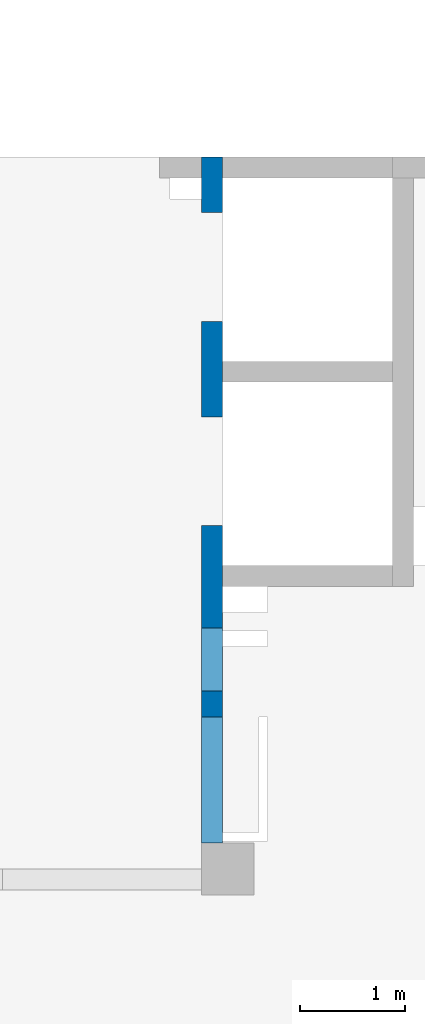
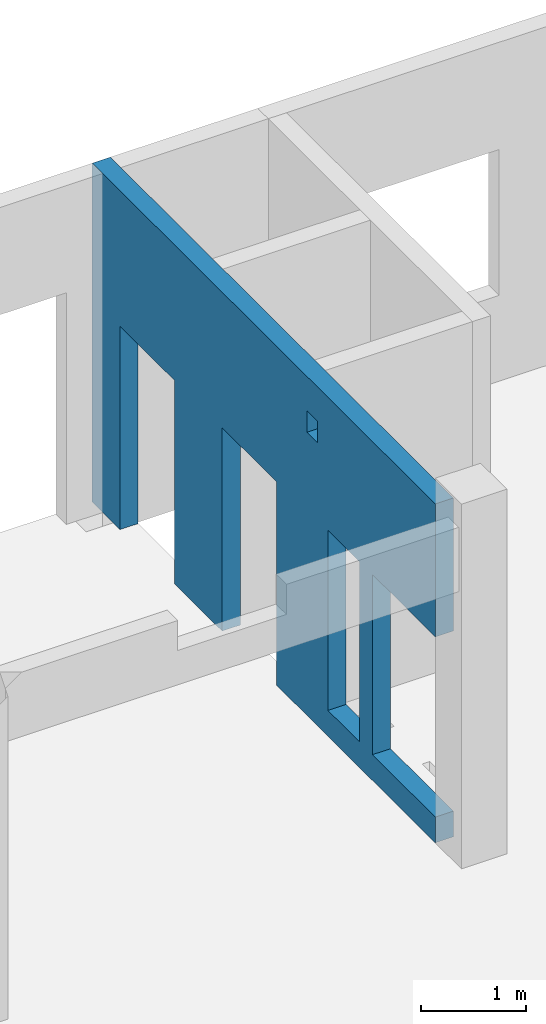
# One storey, part 65 of 67: 1 wall, 5 openings.
"""IFC4 building model written with IfcOpenShell, lengths in millimetres."""

from ifc_helpers import new_model, entity, si_unit, converted_unit, derived_unit, direction, frame, origin, place, context, subcontext, project, spatial, indexed_curve, outline, extrude, polygons, material, type_object, element, save


model = new_model("IFC4")

# Units and contexts
model_context = context("Model", 3, precision=0.01, world=origin(), true_north=direction((6.12303176911189e-17, 1.0)))
plan_context = context("Plan", 3, precision=0.01, world=origin(), true_north=direction((6.12303176911189e-17, 1.0)))
body_context = subcontext(model_context, "Body", "Model", "MODEL_VIEW")
ifc_project = project(units=[si_unit("LENGTHUNIT", "METRE", prefix="MILLI"), si_unit("AREAUNIT", "SQUARE_METRE"), si_unit("VOLUMEUNIT", "CUBIC_METRE"), converted_unit("PLANEANGLEUNIT", "DEGREE", entity("IfcRatioMeasure", 0.0174532925199433), si_unit("PLANEANGLEUNIT", "RADIAN"), dimensions=[0, 0, 0, 0, 0, 0, 0]), si_unit("MASSUNIT", "GRAM", prefix="KILO"), derived_unit("MASSDENSITYUNIT", [(si_unit("MASSUNIT", "GRAM", prefix="KILO"), 1), (si_unit("LENGTHUNIT", "METRE"), -3)]), derived_unit("MOMENTOFINERTIAUNIT", [(si_unit("LENGTHUNIT", "METRE"), 4)]), si_unit("TIMEUNIT", "SECOND"), si_unit("FREQUENCYUNIT", "HERTZ"), si_unit("THERMODYNAMICTEMPERATUREUNIT", "DEGREE_CELSIUS"), derived_unit("THERMALTRANSMITTANCEUNIT", [(si_unit("MASSUNIT", "GRAM", prefix="KILO"), 1), (si_unit("THERMODYNAMICTEMPERATUREUNIT", "KELVIN"), -1), (si_unit("TIMEUNIT", "SECOND"), -3)]), derived_unit("VOLUMETRICFLOWRATEUNIT", [(si_unit("LENGTHUNIT", "METRE"), 3), (si_unit("TIMEUNIT", "SECOND"), -1)]), derived_unit("MASSFLOWRATEUNIT", [(si_unit("MASSUNIT", "GRAM", prefix="KILO"), 1), (si_unit("TIMEUNIT", "SECOND"), -1)]), derived_unit("ROTATIONALFREQUENCYUNIT", [(si_unit("TIMEUNIT", "SECOND"), -1)]), si_unit("ELECTRICCURRENTUNIT", "AMPERE"), si_unit("ELECTRICVOLTAGEUNIT", "VOLT"), si_unit("POWERUNIT", "WATT"), si_unit("FORCEUNIT", "NEWTON", prefix="KILO"), si_unit("ILLUMINANCEUNIT", "LUX"), si_unit("LUMINOUSFLUXUNIT", "LUMEN"), si_unit("LUMINOUSINTENSITYUNIT", "CANDELA"), derived_unit("USERDEFINED", [(si_unit("MASSUNIT", "GRAM", prefix="KILO"), -1), (si_unit("LENGTHUNIT", "METRE"), -2), (si_unit("TIMEUNIT", "SECOND"), 3), (si_unit("LUMINOUSFLUXUNIT", "LUMEN"), 1)]), derived_unit("LINEARVELOCITYUNIT", [(si_unit("LENGTHUNIT", "METRE"), 1), (si_unit("TIMEUNIT", "SECOND"), -1)]), si_unit("PRESSUREUNIT", "PASCAL"), derived_unit("USERDEFINED", [(si_unit("LENGTHUNIT", "METRE"), -2), (si_unit("MASSUNIT", "GRAM", prefix="KILO"), 1), (si_unit("TIMEUNIT", "SECOND"), -2)]), derived_unit("LINEARFORCEUNIT", [(si_unit("MASSUNIT", "GRAM", prefix="KILO"), 1), (si_unit("LENGTHUNIT", "METRE"), 1), (si_unit("TIMEUNIT", "SECOND"), -2), (si_unit("LENGTHUNIT", "METRE"), -1)]), derived_unit("PLANARFORCEUNIT", [(si_unit("MASSUNIT", "GRAM", prefix="KILO"), 1), (si_unit("LENGTHUNIT", "METRE"), 1), (si_unit("TIMEUNIT", "SECOND"), -2), (si_unit("LENGTHUNIT", "METRE"), -2)])], contexts=[model_context, plan_context])

# Site, building, storey
site_placement = place(None, origin())
site = spatial("IfcSite", under=ifc_project, at=site_placement, CompositionType="ELEMENT")
building_placement = place(site_placement, origin())
building = spatial("IfcBuilding", under=site, at=building_placement, CompositionType="ELEMENT")
storey_placement = place(building_placement, frame((0.0, 0.0, 19800.0)))
storey = spatial("IfcBuildingStorey", under=building, at=storey_placement, CompositionType="ELEMENT", Elevation=19800.0)

# Wall, openings
ifc_material = material()
wall_type = type_object("IfcWallType", PredefinedType="STANDARD")
wall_placement = place(storey_placement, frame((16000.0002685547, 20499.9998657227, -150.0), z_axis=(0.0, 0.0, 1.0), x_axis=(0.0, -1.0, 0.0)))
wall = element("IfcWall", 1, at=wall_placement, inside=storey, type_object=wall_type, material=ifc_material, PredefinedType="NOTDEFINED", context=body_context, shape_type="Tessellation", body=[
    polygons([(4100.00063936683, -100.000000000321, 3550.0), (4300.00063936683, -100.00000000032, 3550.0), (4300.00063936683, -100.00000000032, 3300.00000000001), (4100.00063936683, -100.000000000321, 3300.00000000001), (4500.00063936683, -100.000000000002, 2399.99999999998), (5100.00063936683, -100.000000000001, 2399.99999999999), (5100.00063936683, -100.000000000001, 300.000000000001), (4500.00063936683, -100.000000000002, 300.000000000001), (6550.00048980714, -99.999999999998, 3950.0), (399.999999999996, -100.0, 3950.0), (199.999999999998, -100.000000000001, 3950.0), (0.0, -100.000000000001, 3950.0), (0.0, -100.000000000001, 0.0), (199.999999999998, -100.000000000001, 0.0), (529.999999999996, -100.0, 0.0), (529.999999999996, -100.0, 2369.99999999804), (1570.0, -100.000000000003, 2369.99999999805), (1570.0, -100.000000000003, 0.0), (2480.0, -100.000000000001, 0.0), (2480.0, -100.000000000001, 2369.99999999804), (3519.99999999999, -100.000000000001, 2369.99999999805), (3519.99999999999, -100.000000000001, 0.0), (6550.00048980714, -99.999999999998, 0.0), (6550.00048980714, -99.999999999998, 300.000000000001), (5350.00048980714, -100.0, 300.000000000001), (5350.00048980714, -100.0, 2399.99999999998), (6550.00048980714, -99.999999999998, 2399.99999999999), (4300.00063936683, 100.0, 3550.0), (4100.00063936683, 99.9999999999998, 3550.0), (4100.00063936683, 99.9999999999998, 3300.00000000001), (4300.00063936683, 100.0, 3300.00000000001), (5100.00063936683, 99.9999999999994, 2399.99999999999), (4500.00063936683, 99.9999999999983, 2399.99999999998), (4500.00063936683, 99.9999999999983, 300.000000000001), (5100.00063936683, 99.9999999999994, 300.000000000001), (0.0, 99.9999999999989, 3950.0), (1950.0, 100.0, 3950.0), (2150.0, 99.9999999999984, 3950.0), (3900.00063936683, 99.9999999999994, 3950.0), (4100.00063936683, 99.9999999999998, 3950.0), (4300.00063936683, 100.0, 3950.0), (4525.00063936684, 99.9999999999984, 3950.0), (4685.00063936683, 99.9999999999986, 3950.0), (5340.00063936683, 99.9999999999998, 3950.0), (6530.00063936683, 99.9999999999998, 3950.0), (6550.00048980714, 99.9999999999998, 3950.0), (6550.00048980714, 99.9999999999998, 2399.99999999999), (5350.00048980714, 99.9999999999998, 2399.99999999998), (5350.00048980714, 99.9999999999998, 300.000000000001), (6550.00048980714, 99.9999999999998, 300.000000000001), (6550.00048980714, 99.9999999999998, 0.0), (4100.00063936683, 99.9999999999998, 0.0), (3900.00063936683, 99.9999999999994, 0.0), (3519.99999999999, 99.9999999999987, 0.0), (3519.99999999999, 99.9999999999987, 2369.99999999805), (2480.0, 100.000000000001, 2369.99999999804), (2480.0, 100.000000000001, 0.0), (1570.0, 99.9999999999995, 0.0), (1570.0, 99.9999999999995, 2369.99999999805), (529.999999999996, 99.9999999999998, 2369.99999999804), (529.999999999996, 99.9999999999998, 0.0), (0.0, 99.9999999999989, 0.0)], [[[9, 10, 11, 12, 13, 14, 15, 16, 17, 18, 19, 20, 21, 22, 23, 24, 25, 26, 27], [1, 2, 3, 4], [5, 6, 7, 8]], [[36, 37, 38, 39, 40, 41, 42, 43, 44, 45, 46, 47, 48, 49, 50, 51, 52, 53, 54, 55, 56, 57, 58, 59, 60, 61, 62], [28, 29, 30, 31], [32, 33, 34, 35]], [[15, 14, 13, 62, 61]], [[23, 51, 50, 24]], [[12, 11, 10, 9, 46, 45, 44, 43, 42, 41, 40, 39, 38, 37, 36]], [[59, 17, 16, 60]], [[60, 16, 15, 61]], [[17, 59, 58, 18]], [[55, 21, 20, 56]], [[56, 20, 19, 57]], [[21, 55, 54, 22]], [[26, 48, 47, 27]], [[25, 49, 48, 26]], [[49, 25, 24, 50]], [[2, 1, 29, 28]], [[2, 28, 31, 3]], [[3, 31, 30, 4]], [[29, 1, 4, 30]], [[32, 6, 5, 33]], [[33, 5, 8, 34]], [[34, 8, 7, 35]], [[6, 32, 35, 7]], [[13, 12, 36, 62]], [[46, 9, 27, 47]], [[18, 58, 57, 19]], [[51, 23, 22, 54, 53, 52]]], closed=True),
])
opening_1_placement = place(wall_placement, frame((20499.9998657227, -16000.0002685547, 150.0), z_axis=(0.0, 0.0, 1.0), x_axis=(0.0, 1.0, 0.0)))
element("IfcOpeningElement", 2, at=opening_1_placement, cuts=wall, PredefinedType="OPENING", context=body_context, shape_type="SweptSolid", body=[
    extrude(outline(indexed_curve([(-1184.99999999902, -519.999999999999), (1184.99999999902, -519.999999999999), (1184.99999999902, 520.000000000001), (-1184.99999999902, 520.000000000001), (-1184.99999999902, -519.999999999999)], self_intersect=False)), frame((15800.0002685547, 19449.9998657227, 1035.0), z_axis=(1.0, 0.0, 0.0), x_axis=(0.0, 0.0, -1.0)), (0.0, 0.0, 1.0), 400.000000001943),
])
opening_2_placement = place(wall_placement, frame((20499.9998657227, -16000.0002685547, 150.0), z_axis=(0.0, 0.0, 1.0), x_axis=(0.0, 1.0, 0.0)))
element("IfcOpeningElement", 3, at=opening_2_placement, cuts=wall, PredefinedType="OPENING", context=body_context, shape_type="SweptSolid", body=[
    extrude(outline(indexed_curve([(-1184.99999999902, -520.000000000001), (1184.99999999902, -520.000000000001), (1184.99999999902, 519.999999999999), (-1184.99999999902, 519.999999999999), (-1184.99999999902, -520.000000000001)], self_intersect=False)), frame((15800.0002685547, 17499.9998657227, 1035.0), z_axis=(1.0, 0.0, 0.0), x_axis=(0.0, 0.0, -1.0)), (0.0, 0.0, 1.0), 400.000000001943),
])
opening_3_placement = place(wall_placement, frame((20499.9998657227, -16000.0002685547, 150.0), z_axis=(0.0, 0.0, 1.0), x_axis=(0.0, 1.0, 0.0)))
element("IfcOpeningElement", 4, at=opening_3_placement, cuts=wall, PredefinedType="OPENING", context=body_context, shape_type="SweptSolid", body=[
    extrude(outline(indexed_curve([(-1049.99999999999, -600.0), (1050.0, -600.0), (1050.0, 600.0), (-1049.99999999999, 600.0), (-1049.99999999999, -600.0)], self_intersect=False)), frame((15800.0002685547, 14549.9993759155, 1200.0), z_axis=(1.0, 0.0, 0.0), x_axis=(0.0, 0.0, -1.0)), (0.0, 0.0, 1.0), 400.000000001943),
])
opening_4_placement = place(wall_placement, frame((20499.9998657227, -16000.0002685547, 150.0), z_axis=(0.0, 0.0, 1.0), x_axis=(0.0, 1.0, 0.0)))
element("IfcOpeningElement", 5, at=opening_4_placement, cuts=wall, PredefinedType="OPENING", context=body_context, shape_type="SweptSolid", body=[
    extrude(outline(indexed_curve([(-100.000000000001, -124.999999999993), (99.9999999999989, -124.999999999993), (99.9999999999989, 124.999999999993), (-100.000000000001, 124.999999999993), (-100.000000000001, -124.999999999993)], self_intersect=False)), frame((15900.0002685537, 16299.9992263558, 3275.0), z_axis=(1.0, 0.0, 0.0), x_axis=(0.0, -1.0, 0.0)), (0.0, 0.0, 1.0), 200.000000000962),
])
opening_5_placement = place(wall_placement, frame((20499.9998657227, -16000.0002685547, 150.0), z_axis=(0.0, 0.0, 1.0), x_axis=(0.0, 1.0, 0.0)))
element("IfcOpeningElement", 6, at=opening_5_placement, cuts=wall, PredefinedType="OPENING", context=body_context, shape_type="SweptSolid", body=[
    extrude(outline(indexed_curve([(-1049.99999999999, -300.000000000001), (1050.0, -300.000000000001), (1050.0, 299.999999999999), (-1049.99999999999, 299.999999999999), (-1049.99999999999, -300.000000000001)], self_intersect=False)), frame((15800.0002685547, 15699.9992263558, 1200.0), z_axis=(1.0, 0.0, 0.0), x_axis=(0.0, 0.0, -1.0)), (0.0, 0.0, 1.0), 400.000000001943),
])

save(model, "model.ifc")
